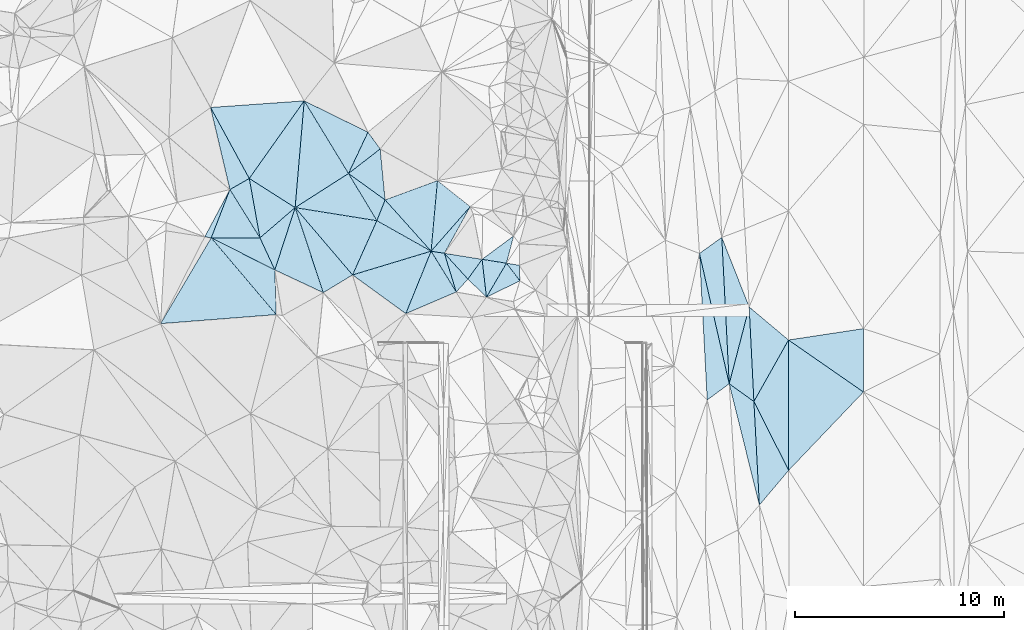
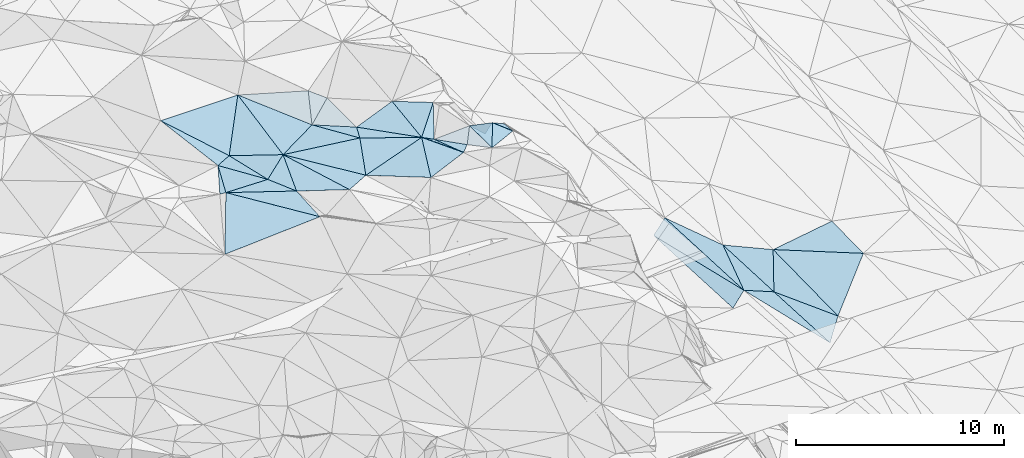
# One storey, part 84 of 275: 45 plates.
"""IFC2X3 building model written with IfcOpenShell, lengths in millimetres."""

from ifc_helpers import new_model, si_unit, frame, origin_with_axes, place, context, subcontext, project, spatial, polyline, outline, extrude, material, type_object, element, save


model = new_model("IFC2X3")

# Units and contexts
model_context = context("Model", 3, precision=1e-05, world=origin_with_axes())
body_context = subcontext(model_context, "Body", "Model", "MODEL_VIEW")
ifc_project = project(units=[si_unit("LENGTHUNIT", "METRE", prefix="MILLI"), si_unit("AREAUNIT", "SQUARE_METRE"), si_unit("VOLUMEUNIT", "CUBIC_METRE"), si_unit("MASSUNIT", "GRAM", prefix="KILO"), si_unit("TIMEUNIT", "SECOND"), si_unit("PLANEANGLEUNIT", "RADIAN"), si_unit("SOLIDANGLEUNIT", "STERADIAN"), si_unit("THERMODYNAMICTEMPERATUREUNIT", "DEGREE_CELSIUS"), si_unit("LUMINOUSINTENSITYUNIT", "LUMEN")], contexts=[model_context])

# Site, building, storey
site_placement = place(None, origin_with_axes())
site = spatial("IfcSite", under=ifc_project, at=site_placement, CompositionType="ELEMENT")
building_placement = place(site_placement, origin_with_axes())
building = spatial("IfcBuilding", under=site, at=building_placement, Name="Undefined", CompositionType="ELEMENT")
storey_placement = place(building_placement, origin_with_axes())
storey = spatial("IfcBuildingStorey", under=building, at=storey_placement, Name="Undefined", CompositionType="ELEMENT", Elevation=0.0)

# Plates
ifc_material = material()
plate_type_1 = type_object("IfcPlateType", PredefinedType="NOTDEFINED")
plate_1_placement = place(storey_placement, frame((-108386.580051783, 88862.7996811773, 52679.50220906), z_axis=(-0.0473780441127211, -0.0815394094291128, -0.995543392146221), x_axis=(0.811245497660078, -0.584632094449101, 0.00927667323509588)))
element("IfcPlate", 1, at=plate_1_placement, inside=storey, type_object=plate_type_1, material=ifc_material, Name="00", context=body_context, shape_type="SweptSolid", body=[
    extrude(outline(polyline([(0.0, 0.0), (2155.9453125, 1.20780896395445e-09), (2419.68115234375, 1039.49194335938), (0.0, 0.0)])), frame((-8.85201319254618e-08, 2.18876761149539e-07, -0.5000001331573), z_axis=(0.0, 0.0, 1.0), x_axis=(1.0, 0.0, 0.0)), (0.0, 0.0, 1.0), 1.0),
])
plate_type_2 = type_object("IfcPlateType", PredefinedType="NOTDEFINED")
plate_2_placement = place(storey_placement, frame((-110935.188256304, 87233.1552886086, 52809.5025149731), z_axis=(0.0909211524705096, 0.0429663560057354, -0.994930769594057), x_axis=(-0.842542661091753, 0.535930910773084, -0.0538509342385081)))
element("IfcPlate", 2, at=plate_2_placement, inside=storey, type_object=plate_type_2, material=ifc_material, Name="00", context=body_context, shape_type="SweptSolid", body=[
    extrude(outline(polyline([(0.0, 0.0), (2599.76928710938, 2.09729478228837e-09), (2353.90112304688, 4553.94873046875), (0.0, 0.0)])), frame((-8.85201319254618e-08, 2.18876761149539e-07, -0.5000001331573), z_axis=(0.0, 0.0, 1.0), x_axis=(1.0, 0.0, 0.0)), (0.0, 0.0, 1.0), 1.0),
])
plate_type_3 = type_object("IfcPlateType", PredefinedType="NOTDEFINED")
plate_3_placement = place(storey_placement, frame((-114050.664548949, 88097.1968443892, 52739.5005654492), z_axis=(-0.0171309228286942, -0.0453009128549902, -0.998826490826881), x_axis=(0.52807049744489, -0.848690256273745, 0.029434650232553)))
element("IfcPlate", 3, at=plate_3_placement, inside=storey, type_object=plate_type_3, material=ifc_material, Name="00", context=body_context, shape_type="SweptSolid", body=[
    extrude(outline(polyline([(0.0, 0.0), (2717.88525390625, -1.81898940354586e-09), (1490.90185546875, 1979.04309082031), (0.0, 0.0)])), frame((-8.85201319254618e-08, 2.18876761149539e-07, -0.5000001331573), z_axis=(0.0, 0.0, 1.0), x_axis=(1.0, 0.0, 0.0)), (0.0, 0.0, 1.0), 1.0),
])
plate_type_4 = type_object("IfcPlateType", PredefinedType="NOTDEFINED")
plate_4_placement = place(storey_placement, frame((-112615.44152599, 85790.5467316881, 52819.5013071815), z_axis=(-0.0410658751826201, -0.0601422838124881, -0.997344724552802), x_axis=(-0.528070497442387, 0.848690256275381, -0.0294346502302673)))
element("IfcPlate", 4, at=plate_4_placement, inside=storey, type_object=plate_type_4, material=ifc_material, Name="00", context=body_context, shape_type="SweptSolid", body=[
    extrude(outline(polyline([(0.0, 0.0), (2717.88525390625, -1.81898940354586e-09), (2680.61352539063, 1067.33825683594), (0.0, 0.0)])), frame((-8.85201319254618e-08, 2.18876761149539e-07, -0.5000001331573), z_axis=(0.0, 0.0, 1.0), x_axis=(1.0, 0.0, 0.0)), (0.0, 0.0, 1.0), 1.0),
])
plate_type_5 = type_object("IfcPlateType", PredefinedType="NOTDEFINED")
plate_5_placement = place(storey_placement, frame((-104439.082211446, 85152.0740761897, 52809.5021817556), z_axis=(-0.0429967599848049, -0.0832734143644725, -0.995598722925503), x_axis=(-0.871575199290287, 0.490250293904377, -0.00336471525813851)))
element("IfcPlate", 5, at=plate_5_placement, inside=storey, type_object=plate_type_5, material=ifc_material, Name="00", context=body_context, shape_type="SweptSolid", body=[
    extrude(outline(polyline([(0.0, 0.0), (2972.01953125, -9.47693479247391e-09), (3117.77905273438, 1062.47546386719), (0.0, 0.0)])), frame((-8.85201319254618e-08, 2.18876761149539e-07, -0.5000001331573), z_axis=(0.0, 0.0, 1.0), x_axis=(1.0, 0.0, 0.0)), (0.0, 0.0, 1.0), 1.0),
])
plate_type_6 = type_object("IfcPlateType", PredefinedType="NOTDEFINED")
plate_6_placement = place(storey_placement, frame((-87365.5688585575, 80909.3780213733, 42819.5002070441), z_axis=(0.0221465759152857, 0.0198452153937442, -0.999557750508296), x_axis=(0.98839121279668, 0.149880120603403, 0.0248748852101583)))
element("IfcPlate", 6, at=plate_6_placement, inside=storey, type_object=plate_type_6, material=ifc_material, Name="00", context=body_context, shape_type="SweptSolid", body=[
    extrude(outline(polyline([(0.0, 0.0), (3618.10717773438, -2.9831426218152e-09), (3167.12548828125, 2993.5791015625), (0.0, 0.0)])), frame((-8.85201319254618e-08, 2.18876761149539e-07, -0.5000001331573), z_axis=(0.0, 0.0, 1.0), x_axis=(1.0, 0.0, 0.0)), (0.0, 0.0, 1.0), 1.0),
])
plate_type_7 = type_object("IfcPlateType", PredefinedType="NOTDEFINED")
plate_7_placement = place(storey_placement, frame((-90196.6322116075, 78818.0444461295, 42687.5079163756), z_axis=(0.174846447314894, 0.0298121499985753, -0.984144275791829), x_axis=(-0.795259158075311, -0.585045632729329, -0.15901094025785)))
element("IfcPlate", 7, at=plate_7_placement, inside=storey, type_object=plate_type_7, material=ifc_material, Name="00", context=body_context, shape_type="SweptSolid", body=[
    extrude(outline(polyline([(0.0, 0.0), (1320.66381835938, 1.06228981167078e-09), (-2501.51391601563, 5876.05078125), (0.0, 0.0)])), frame((-8.85201319254618e-08, 2.18876761149539e-07, -0.5000001331573), z_axis=(0.0, 0.0, 1.0), x_axis=(1.0, 0.0, 0.0)), (0.0, 0.0, 1.0), 1.0),
])
plate_type_8 = type_object("IfcPlateType", PredefinedType="NOTDEFINED")
plate_8_placement = place(storey_placement, frame((-102569.851096653, 87279.8264456317, 52919.5566958775), z_axis=(-0.323814668468676, 0.33035846241017, -0.886570553762367), x_axis=(-0.478982492871626, -0.865343068309801, -0.147503036072694)))
element("IfcPlate", 8, at=plate_8_placement, inside=storey, type_object=plate_type_8, material=ifc_material, Name="00", context=body_context, shape_type="SweptSolid", body=[
    extrude(outline(polyline([(0.0, 0.0), (2576.21826171875, 2.00525391846895e-08), (2752.67846679688, 675.175354003906), (0.0, 0.0)])), frame((-8.85201319254618e-08, 2.18876761149539e-07, -0.5000001331573), z_axis=(0.0, 0.0, 1.0), x_axis=(1.0, 0.0, 0.0)), (0.0, 0.0, 1.0), 1.0),
])
plate_type_9 = type_object("IfcPlateType", PredefinedType="NOTDEFINED")
plate_9_placement = place(storey_placement, frame((-90196.7069356175, 78818.0401369542, 42687.5002602962), z_axis=(0.0254223780452323, 0.0211891597521177, -0.999452211065404), x_axis=(0.251652546433601, 0.967443413523056, 0.0269116611219287)))
element("IfcPlate", 9, at=plate_9_placement, inside=storey, type_object=plate_type_9, material=ifc_material, Name="00", context=body_context, shape_type="SweptSolid", body=[
    extrude(outline(polyline([(0.0, 0.0), (3790.17846679688, 9.61881596595049e-09), (-523.401977539063, 1354.22424316406), (0.0, 0.0)])), frame((-8.85201319254618e-08, 2.18876761149539e-07, -0.5000001331573), z_axis=(0.0, 0.0, 1.0), x_axis=(1.0, 0.0, 0.0)), (0.0, 0.0, 1.0), 1.0),
])
plate_type_10 = type_object("IfcPlateType", PredefinedType="NOTDEFINED")
plate_10_placement = place(storey_placement, frame((-89242.8945265137, 82484.823568676, 42789.5003946455), z_axis=(0.0341071068266466, 0.021616004348828, -0.999184394203546), x_axis=(0.765951622118236, -0.642781685216068, 0.0122400051157735)))
element("IfcPlate", 10, at=plate_10_placement, inside=storey, type_object=plate_type_10, material=ifc_material, Name="00", context=body_context, shape_type="SweptSolid", body=[
    extrude(outline(polyline([(0.0, 0.0), (2450.9794921875, 5.77529135625809e-10), (3072.93481445313, 3316.31884765625), (0.0, 0.0)])), frame((-8.85201319254618e-08, 2.18876761149539e-07, -0.5000001331573), z_axis=(0.0, 0.0, 1.0), x_axis=(1.0, 0.0, 0.0)), (0.0, 0.0, 1.0), 1.0),
])
plate_type_11 = type_object("IfcPlateType", PredefinedType="NOTDEFINED")
plate_11_placement = place(storey_placement, frame((-114943.62580473, 85789.0516893204, 52859.5000689306), z_axis=(-0.0171724047605289, -0.00795913818449715, -0.999820864272246), x_axis=(0.999852231399842, 0.000653254230612618, -0.0171781437782944)))
element("IfcPlate", 11, at=plate_11_placement, inside=storey, type_object=plate_type_11, material=ifc_material, Name="00", context=body_context, shape_type="SweptSolid", body=[
    extrude(outline(polyline([(0.0, 0.0), (2328.54028320313, -1.19325704872608e-09), (3038.21240234375, 1534.068359375), (0.0, 0.0)])), frame((-8.85201319254618e-08, 2.18876761149539e-07, -0.5000001331573), z_axis=(0.0, 0.0, 1.0), x_axis=(1.0, 0.0, 0.0)), (0.0, 0.0, 1.0), 1.0),
])
plate_type_12 = type_object("IfcPlateType", PredefinedType="NOTDEFINED")
plate_12_placement = place(storey_placement, frame((-100496.145371751, 85878.1015995437, 51179.67594565), z_axis=(-0.184249683621059, -0.738953221485208, -0.648074216847247), x_axis=(-0.165664651089674, -0.626581207265257, 0.761545280388074)))
element("IfcPlate", 12, at=plate_12_placement, inside=storey, type_object=plate_type_12, material=ifc_material, Name="00", context=body_context, shape_type="SweptSolid", body=[
    extrude(outline(polyline([(0.0, 0.0), (2074.72900390625, 2.35741026699543e-09), (2243.0400390625, 1172.93286132813), (0.0, 0.0)])), frame((-8.85201319254618e-08, 2.18876761149539e-07, -0.5000001331573), z_axis=(0.0, 0.0, 1.0), x_axis=(1.0, 0.0, 0.0)), (0.0, 0.0, 1.0), 1.0),
])
plate_type_13 = type_object("IfcPlateType", PredefinedType="NOTDEFINED")
plate_13_placement = place(storey_placement, frame((-90196.7075435128, 78818.0392869851, 42687.5002243836), z_axis=(0.0241860014844724, 0.0194698134309543, -0.999517865621799), x_axis=(0.811704490584274, -0.584009849785009, 0.00826530818629343)))
element("IfcPlate", 13, at=plate_13_placement, inside=storey, type_object=plate_type_13, material=ifc_material, Name="00", context=body_context, shape_type="SweptSolid", body=[
    extrude(outline(polyline([(0.0, 0.0), (1451.8515625, -1.21181074064225e-08), (4552.7744140625, 3863.53149414063), (0.0, 0.0)])), frame((-8.85201319254618e-08, 2.18876761149539e-07, -0.5000001331573), z_axis=(0.0, 0.0, 1.0), x_axis=(1.0, 0.0, 0.0)), (0.0, 0.0, 1.0), 1.0),
])
plate_type_14 = type_object("IfcPlateType", PredefinedType="NOTDEFINED")
plate_14_placement = place(storey_placement, frame((-103803.692304363, 85050.29638164, 52539.5043197901), z_axis=(-0.079431329158167, -0.104732474381509, -0.991323243325856), x_axis=(0.674026666099184, -0.738317198775976, 0.0239951532359128)))
element("IfcPlate", 14, at=plate_14_placement, inside=storey, type_object=plate_type_14, material=ifc_material, Name="00", context=body_context, shape_type="SweptSolid", body=[
    extrude(outline(polyline([(0.0, 0.0), (1667.00329589844, 1.21508492156863e-08), (1750.26647949219, 835.683715820313), (0.0, 0.0)])), frame((-8.85201319254618e-08, 2.18876761149539e-07, -0.5000001331573), z_axis=(0.0, 0.0, 1.0), x_axis=(1.0, 0.0, 0.0)), (0.0, 0.0, 1.0), 1.0),
])
plate_type_15 = type_object("IfcPlateType", PredefinedType="NOTDEFINED")
plate_15_placement = place(storey_placement, frame((-101794.235559156, 82953.8547880419, 52609.5168145792), z_axis=(0.195836438012691, 0.166857271893424, -0.966336763433321), x_axis=(-0.714890506026088, 0.698817032693059, -0.024214029235816)))
element("IfcPlate", 15, at=plate_15_placement, inside=storey, type_object=plate_type_15, material=ifc_material, Name="00", context=body_context, shape_type="SweptSolid", body=[
    extrude(outline(polyline([(0.0, 0.0), (1238.951171875, -1.43700162880123e-09), (1408.04577636719, 1187.2265625), (0.0, 0.0)])), frame((-8.85201319254618e-08, 2.18876761149539e-07, -0.5000001331573), z_axis=(0.0, 0.0, 1.0), x_axis=(1.0, 0.0, 0.0)), (0.0, 0.0, 1.0), 1.0),
])
plate_type_16 = type_object("IfcPlateType", PredefinedType="NOTDEFINED")
plate_16_placement = place(storey_placement, frame((-102004.043375566, 84763.6023774129, 52879.5063794252), z_axis=(-0.079812946958229, 0.13803544257929, -0.987206214572104), x_axis=(0.98252557942757, -0.156165956834787, -0.101270329793049)))
element("IfcPlate", 16, at=plate_16_placement, inside=storey, type_object=plate_type_16, material=ifc_material, Name="00", context=body_context, shape_type="SweptSolid", body=[
    extrude(outline(polyline([(0.0, 0.0), (1184.947265625, 1.03318598121405e-09), (515.972351074219, 1768.013671875), (0.0, 0.0)])), frame((-8.85201319254618e-08, 2.18876761149539e-07, -0.5000001331573), z_axis=(0.0, 0.0, 1.0), x_axis=(1.0, 0.0, 0.0)), (0.0, 0.0, 1.0), 1.0),
])
plate_type_17 = type_object("IfcPlateType", PredefinedType="NOTDEFINED")
plate_17_placement = place(storey_placement, frame((-100839.934150185, 84578.4648306573, 52759.5308060635), z_axis=(-0.343332692926057, -0.0402186716529135, -0.938352343428958), x_axis=(0.930179919547813, -0.152798132893854, -0.333793420927041)))
element("IfcPlate", 17, at=plate_17_placement, inside=storey, type_object=plate_type_17, material=ifc_material, Name="00", context=body_context, shape_type="SweptSolid", body=[
    extrude(outline(polyline([(0.0, 0.0), (659.090270996094, 3.01224645227194e-09), (795.338684082031, 728.585205078125), (0.0, 0.0)])), frame((-8.85201319254618e-08, 2.18876761149539e-07, -0.5000001331573), z_axis=(0.0, 0.0, 1.0), x_axis=(1.0, 0.0, 0.0)), (0.0, 0.0, 1.0), 1.0),
])
plate_type_18 = type_object("IfcPlateType", PredefinedType="NOTDEFINED")
plate_18_placement = place(storey_placement, frame((-91618.3886218002, 85043.8021222997, 42623.5073159665), z_axis=(0.168211243000226, 0.0282845492018912, -0.985345097924968), x_axis=(0.802293724824646, 0.576850243562442, 0.153520603206693)))
element("IfcPlate", 18, at=plate_18_placement, inside=storey, type_object=plate_type_18, material=ifc_material, Name="00", context=body_context, shape_type="SweptSolid", body=[
    extrude(outline(polyline([(0.0, 0.0), (1328.81188964844, 3.87080945074558e-09), (-2440.84130859375, 5901.51171875), (0.0, 0.0)])), frame((-8.85201319254618e-08, 2.18876761149539e-07, -0.5000001331573), z_axis=(0.0, 0.0, 1.0), x_axis=(1.0, 0.0, 0.0)), (0.0, 0.0, 1.0), 1.0),
])
plate_type_19 = type_object("IfcPlateType", PredefinedType="NOTDEFINED")
plate_19_placement = place(storey_placement, frame((-100839.815333368, 84578.5613084166, 52759.5086729945), z_axis=(-0.105539493372001, 0.1527269008104, -0.982616867913243), x_axis=(0.598108272684796, -0.779669487932432, -0.185423794948729)))
element("IfcPlate", 19, at=plate_19_placement, inside=storey, type_object=plate_type_19, material=ifc_material, Name="00", context=body_context, shape_type="SweptSolid", body=[
    extrude(outline(polyline([(0.0, 0.0), (1078.61022949219, 3.09591996483505e-09), (723.616333007813, 1746.36169433594), (0.0, 0.0)])), frame((-8.85201319254618e-08, 2.18876761149539e-07, -0.5000001331573), z_axis=(0.0, 0.0, 1.0), x_axis=(1.0, 0.0, 0.0)), (0.0, 0.0, 1.0), 1.0),
])
plate_type_20 = type_object("IfcPlateType", PredefinedType="NOTDEFINED")
plate_20_placement = place(storey_placement, frame((-103237.877538802, 83201.2051087369, 52689.5547884111), z_axis=(-0.410015527839808, -0.197733789193882, -0.890386778619984), x_axis=(-0.523660923465364, 0.850319565303489, 0.0523055838079288)))
element("IfcPlate", 20, at=plate_20_placement, inside=storey, type_object=plate_type_20, material=ifc_material, Name="00", context=body_context, shape_type="SweptSolid", body=[
    extrude(outline(polyline([(0.0, 0.0), (2294.21020507813, 9.95351001620293e-09), (1860.81469726563, 546.962951660156), (0.0, 0.0)])), frame((-8.85201319254618e-08, 2.18876761149539e-07, -0.5000001331573), z_axis=(0.0, 0.0, 1.0), x_axis=(1.0, 0.0, 0.0)), (0.0, 0.0, 1.0), 1.0),
])
plate_type_21 = type_object("IfcPlateType", PredefinedType="NOTDEFINED")
plate_21_placement = place(storey_placement, frame((-103803.548797934, 85050.4278144353, 52539.5173054603), z_axis=(0.207581799523381, 0.158132446715465, -0.965351710933593), x_axis=(0.97078564103455, -0.154716970771224, 0.18340637425268)))
element("IfcPlate", 21, at=plate_21_placement, inside=storey, type_object=plate_type_21, material=ifc_material, Name="00", context=body_context, shape_type="SweptSolid", body=[
    extrude(outline(polyline([(0.0, 0.0), (1853.80688476563, 4.46743797510862e-09), (1288.53771972656, 1057.625), (0.0, 0.0)])), frame((-8.85201319254618e-08, 2.18876761149539e-07, -0.5000001331573), z_axis=(0.0, 0.0, 1.0), x_axis=(1.0, 0.0, 0.0)), (0.0, 0.0, 1.0), 1.0),
])
plate_type_22 = type_object("IfcPlateType", PredefinedType="NOTDEFINED")
plate_22_placement = place(storey_placement, frame((-108190.947801121, 84018.2621437385, 52589.5013674836), z_axis=(0.039382820234934, 0.0631712203224884, -0.997225345843812), x_axis=(0.407977379961261, 0.910007789585465, 0.0737582560376859)))
element("IfcPlate", 22, at=plate_22_placement, inside=storey, type_object=plate_type_22, material=ifc_material, Name="00", context=body_context, shape_type="SweptSolid", body=[
    extrude(outline(polyline([(0.0, 0.0), (2847.13891601563, -5.64614310860634e-09), (2578.76416015625, 2959.87744140625), (0.0, 0.0)])), frame((-8.85201319254618e-08, 2.18876761149539e-07, -0.5000001331573), z_axis=(0.0, 0.0, 1.0), x_axis=(1.0, 0.0, 0.0)), (0.0, 0.0, 1.0), 1.0),
])
plate_type_23 = type_object("IfcPlateType", PredefinedType="NOTDEFINED")
plate_23_placement = place(storey_placement, frame((-114943.619149979, 85789.0921033081, 52859.5013126928), z_axis=(-0.00388868035268274, 0.0728686466082565, -0.997333965383008), x_axis=(0.645517390053446, -0.761528126703473, -0.0581567827350032)))
element("IfcPlate", 23, at=plate_23_placement, inside=storey, type_object=plate_type_23, material=ifc_material, Name="00", context=body_context, shape_type="SweptSolid", body=[
    extrude(outline(polyline([(0.0, 0.0), (4814.57177734375, -8.30186763778329e-09), (1575.98657226563, 4500.0185546875), (0.0, 0.0)])), frame((-8.85201319254618e-08, 2.18876761149539e-07, -0.5000001331573), z_axis=(0.0, 0.0, 1.0), x_axis=(1.0, 0.0, 0.0)), (0.0, 0.0, 1.0), 1.0),
])
plate_type_24 = type_object("IfcPlateType", PredefinedType="NOTDEFINED")
plate_24_placement = place(storey_placement, frame((-104439.071114851, 85152.1400095212, 52809.5006813522), z_axis=(-0.0208248110341935, 0.0486020499990452, -0.998601105537782), x_axis=(0.523660923467584, -0.85031956530281, -0.0523055837967336)))
element("IfcPlate", 24, at=plate_24_placement, inside=storey, type_object=plate_type_24, material=ifc_material, Name="00", context=body_context, shape_type="SweptSolid", body=[
    extrude(outline(polyline([(0.0, 0.0), (2294.21020507813, 9.95351001620293e-09), (1910.50500488281, 2591.92407226563), (0.0, 0.0)])), frame((-8.85201319254618e-08, 2.18876761149539e-07, -0.5000001331573), z_axis=(0.0, 0.0, 1.0), x_axis=(1.0, 0.0, 0.0)), (0.0, 0.0, 1.0), 1.0),
])
plate_type_25 = type_object("IfcPlateType", PredefinedType="NOTDEFINED")
plate_25_placement = place(storey_placement, frame((-109587.732705049, 83171.1292379902, 52749.5001789872), z_axis=(-0.0275663468032675, 0.00562042020970078, -0.999604175361722), x_axis=(-0.905144797437824, 0.424222883953875, 0.0273466707497939)))
element("IfcPlate", 25, at=plate_25_placement, inside=storey, type_object=plate_type_25, material=ifc_material, Name="00", context=body_context, shape_type="SweptSolid", body=[
    extrude(outline(polyline([(0.0, 0.0), (2559.7265625, 1.80807546712458e-09), (2944.533203125, 3106.28784179688), (0.0, 0.0)])), frame((-8.85201319254618e-08, 2.18876761149539e-07, -0.5000001331573), z_axis=(0.0, 0.0, 1.0), x_axis=(1.0, 0.0, 0.0)), (0.0, 0.0, 1.0), 1.0),
])
plate_26_placement = place(storey_placement, frame((-108386.497309168, 88862.9312482766, 52679.5118522026), z_axis=(0.118098477560666, 0.181597927885993, -0.976255572166104), x_axis=(-0.517770164145949, 0.850171756804636, 0.0955093767752439)))
element("IfcPlate", 26, at=plate_26_placement, inside=storey, type_object=plate_type_25, material=ifc_material, Name="00", context=body_context, shape_type="SweptSolid", body=[
    extrude(outline(polyline([(0.0, 0.0), (4083.36865234375, 3.06172296404839e-08), (1242.99328613281, 1858.16247558594), (0.0, 0.0)])), frame((-8.85201319254618e-08, 2.18876761149539e-07, -0.5000001331573), z_axis=(0.0, 0.0, 1.0), x_axis=(1.0, 0.0, 0.0)), (0.0, 0.0, 1.0), 1.0),
])
plate_type_26 = type_object("IfcPlateType", PredefinedType="NOTDEFINED")
plate_27_placement = place(storey_placement, frame((-110935.228882847, 87233.1720420922, 52809.5014679808), z_axis=(0.00966524728515323, 0.0764780040069057, -0.997024421916553), x_axis=(0.98747487307498, -0.157756087763076, -0.0025282047465476)))
element("IfcPlate", 27, at=plate_27_placement, inside=storey, type_object=plate_type_26, material=ifc_material, Name="00", context=body_context, shape_type="SweptSolid", body=[
    extrude(outline(polyline([(0.0, 0.0), (3955.3759765625, -1.86701072379947e-08), (3217.62060546875, 2749.89404296875), (0.0, 0.0)])), frame((-8.85201319254618e-08, 2.18876761149539e-07, -0.5000001331573), z_axis=(0.0, 0.0, 1.0), x_axis=(1.0, 0.0, 0.0)), (0.0, 0.0, 1.0), 1.0),
])
plate_type_27 = type_object("IfcPlateType", PredefinedType="NOTDEFINED")
plate_28_placement = place(storey_placement, frame((-111835.705546149, 82122.680471372, 52579.5036705222), z_axis=(0.0439175419480246, 0.113032119386767, -0.992620264500065), x_axis=(-0.645517390070698, 0.761528126687722, 0.0581567827497589)))
element("IfcPlate", 28, at=plate_28_placement, inside=storey, type_object=plate_type_27, material=ifc_material, Name="00", context=body_context, shape_type="SweptSolid", body=[
    extrude(outline(polyline([(0.0, 0.0), (4814.57177734375, -8.30186763778329e-09), (1683.84655761719, 1335.16320800781), (0.0, 0.0)])), frame((-8.85201319254618e-08, 2.18876761149539e-07, -0.5000001331573), z_axis=(0.0, 0.0, 1.0), x_axis=(1.0, 0.0, 0.0)), (0.0, 0.0, 1.0), 1.0),
])
plate_type_28 = type_object("IfcPlateType", PredefinedType="NOTDEFINED")
plate_29_placement = place(storey_placement, frame((-114975.116809154, 92018.3344901174, 53319.5080506407), z_axis=(-0.138970277764861, 0.112768761218131, -0.983854902102584), x_axis=(0.472076926357198, -0.865802681136365, -0.165918934839342)))
element("IfcPlate", 29, at=plate_29_placement, inside=storey, type_object=plate_type_28, material=ifc_material, Name="00", context=body_context, shape_type="SweptSolid", body=[
    extrude(outline(polyline([(0.0, 0.0), (3917.57568359375, 9.03673935681582e-09), (3927.47998046875, 1067.94287109375), (0.0, 0.0)])), frame((-8.85201319254618e-08, 2.18876761149539e-07, -0.5000001331573), z_axis=(0.0, 0.0, 1.0), x_axis=(1.0, 0.0, 0.0)), (0.0, 0.0, 1.0), 1.0),
])
plate_type_29 = type_object("IfcPlateType", PredefinedType="NOTDEFINED")
plate_30_placement = place(storey_placement, frame((-111904.644225525, 84257.0200206297, 52819.4999860023), z_axis=(-0.00425746446713632, -0.00197326776800877, -0.999988990044704), x_axis=(-0.420512976306107, 0.907286524069535, -1.99704337322955e-10)))
element("IfcPlate", 30, at=plate_30_placement, inside=storey, type_object=plate_type_29, material=ifc_material, Name="00", context=body_context, shape_type="SweptSolid", body=[
    extrude(outline(polyline([(0.0, 0.0), (1690.26623535156, -1.41590135172009e-08), (2292.53833007813, 2131.04858398438), (0.0, 0.0)])), frame((-8.85201319254618e-08, 2.18876761149539e-07, -0.5000001331573), z_axis=(0.0, 0.0, 1.0), x_axis=(1.0, 0.0, 0.0)), (0.0, 0.0, 1.0), 1.0),
])
plate_type_30 = type_object("IfcPlateType", PredefinedType="NOTDEFINED")
plate_31_placement = place(storey_placement, frame((-114050.64468482, 88097.1891823581, 52739.5010267622), z_axis=(0.0225959808703213, -0.0606221848125656, -0.997904991648533), x_axis=(-0.360387435734755, -0.931544625929087, 0.0484304250153309)))
element("IfcPlate", 31, at=plate_31_placement, inside=storey, type_object=plate_type_30, material=ifc_material, Name="00", context=body_context, shape_type="SweptSolid", body=[
    extrude(outline(polyline([(0.0, 0.0), (2477.78125, -2.70665623247623e-09), (2540.86181640625, 304.336700439453), (0.0, 0.0)])), frame((-8.85201319254618e-08, 2.18876761149539e-07, -0.5000001331573), z_axis=(0.0, 0.0, 1.0), x_axis=(1.0, 0.0, 0.0)), (0.0, 0.0, 1.0), 1.0),
])
plate_type_31 = type_object("IfcPlateType", PredefinedType="NOTDEFINED")
plate_32_placement = place(storey_placement, frame((-104439.042496764, 85152.1096273866, 52809.5003501096), z_axis=(0.036432415555792, -0.0121709457058364, -0.999262001267633), x_axis=(-0.667455895850086, 0.743900099503683, -0.0333956442275059)))
element("IfcPlate", 32, at=plate_32_placement, inside=storey, type_object=plate_type_31, material=ifc_material, Name="00", context=body_context, shape_type="SweptSolid", body=[
    extrude(outline(polyline([(0.0, 0.0), (3293.8427734375, 2.59387888945639e-09), (2305.90844726563, 2476.8701171875), (0.0, 0.0)])), frame((-8.85201319254618e-08, 2.18876761149539e-07, -0.5000001331573), z_axis=(0.0, 0.0, 1.0), x_axis=(1.0, 0.0, 0.0)), (0.0, 0.0, 1.0), 1.0),
])
plate_type_32 = type_object("IfcPlateType", PredefinedType="NOTDEFINED")
plate_33_placement = place(storey_placement, frame((-108190.941053848, 84018.2399488011, 52589.5007681111), z_axis=(0.0528710219463386, 0.0187729144707353, -0.998424875852272), x_axis=(0.955736204306891, 0.288838490334365, 0.0560413622106128)))
element("IfcPlate", 33, at=plate_33_placement, inside=storey, type_object=plate_type_32, material=ifc_material, Name="00", context=body_context, shape_type="SweptSolid", body=[
    extrude(outline(polyline([(0.0, 0.0), (3925.671875, 8.13452061265707e-09), (1903.82690429688, 2506.04125976563), (0.0, 0.0)])), frame((-8.85201319254618e-08, 2.18876761149539e-07, -0.5000001331573), z_axis=(0.0, 0.0, 1.0), x_axis=(1.0, 0.0, 0.0)), (0.0, 0.0, 1.0), 1.0),
])
plate_type_33 = type_object("IfcPlateType", PredefinedType="NOTDEFINED")
plate_34_placement = place(storey_placement, frame((-113125.633130304, 88626.4071614112, 52669.5008159407), z_axis=(0.0341242266044759, -0.0466660011787229, -0.998327512138493), x_axis=(0.842542661096068, -0.535930910766295, 0.0538509342385591)))
element("IfcPlate", 34, at=plate_34_placement, inside=storey, type_object=plate_type_33, material=ifc_material, Name="00", context=body_context, shape_type="SweptSolid", body=[
    extrude(outline(polyline([(0.0, 0.0), (2599.76928710938, 2.09729478228837e-09), (1957.78918457031, 2119.4248046875), (0.0, 0.0)])), frame((-8.85201319254618e-08, 2.18876761149539e-07, -0.5000001331573), z_axis=(0.0, 0.0, 1.0), x_axis=(1.0, 0.0, 0.0)), (0.0, 0.0, 1.0), 1.0),
])
plate_type_34 = type_object("IfcPlateType", PredefinedType="NOTDEFINED")
plate_35_placement = place(storey_placement, frame((-104439.022411876, 85152.1078303685, 52809.501513471), z_axis=(0.0766028365728152, -0.0157628033599301, -0.996937078987052), x_axis=(0.0895656547289487, 0.995941466796266, -0.00886499907933091)))
element("IfcPlate", 35, at=plate_35_placement, inside=storey, type_object=plate_type_34, material=ifc_material, Name="00", context=body_context, shape_type="SweptSolid", body=[
    extrude(outline(polyline([(0.0, 0.0), (3384.09521484375, 1.04773789644241e-09), (2285.3671875, 1676.36413574219), (0.0, 0.0)])), frame((-8.85201319254618e-08, 2.18876761149539e-07, -0.5000001331573), z_axis=(0.0, 0.0, 1.0), x_axis=(1.0, 0.0, 0.0)), (0.0, 0.0, 1.0), 1.0),
])
plate_type_35 = type_object("IfcPlateType", PredefinedType="NOTDEFINED")
plate_36_placement = place(storey_placement, frame((-110935.284850461, 87233.1241864925, 52809.5026935832), z_axis=(-0.102264567662067, -0.0192340221795908, -0.994571269739723), x_axis=(0.648362420193751, -0.759555478832517, -0.051977366766767)))
element("IfcPlate", 36, at=plate_36_placement, inside=storey, type_object=plate_type_35, material=ifc_material, Name="00", context=body_context, shape_type="SweptSolid", body=[
    extrude(outline(polyline([(0.0, 0.0), (4232.611328125, 8.38190317153931e-09), (3962.11645507813, 1618.92944335938), (0.0, 0.0)])), frame((-8.85201319254618e-08, 2.18876761149539e-07, -0.5000001331573), z_axis=(0.0, 0.0, 1.0), x_axis=(1.0, 0.0, 0.0)), (0.0, 0.0, 1.0), 1.0),
])
plate_type_36 = type_object("IfcPlateType", PredefinedType="NOTDEFINED")
plate_37_placement = place(storey_placement, frame((-106637.499342742, 87602.4757319184, 52699.508108005), z_axis=(0.112258544333662, 0.140162277078866, -0.983744151346352), x_axis=(-0.81124549766041, 0.584632094448409, -0.0092766732496751)))
element("IfcPlate", 37, at=plate_37_placement, inside=storey, type_object=plate_type_36, material=ifc_material, Name="00", context=body_context, shape_type="SweptSolid", body=[
    extrude(outline(polyline([(0.0, 0.0), (2155.9453125, 1.20780896395445e-09), (1609.27087402344, 1867.60461425781), (0.0, 0.0)])), frame((-8.85201319254618e-08, 2.18876761149539e-07, -0.5000001331573), z_axis=(0.0, 0.0, 1.0), x_axis=(1.0, 0.0, 0.0)), (0.0, 0.0, 1.0), 1.0),
])
plate_type_37 = type_object("IfcPlateType", PredefinedType="NOTDEFINED")
plate_38_placement = place(storey_placement, frame((-108386.56246986, 88862.8101969258, 52679.5009335227), z_axis=(-0.0122213398273442, -0.0605040519011654, -0.99809313120388), x_axis=(0.515340626459626, -0.855773179357589, 0.0455664812378989)))
element("IfcPlate", 38, at=plate_38_placement, inside=storey, type_object=plate_type_37, material=ifc_material, Name="00", context=body_context, shape_type="SweptSolid", body=[
    extrude(outline(polyline([(0.0, 0.0), (2633.5146484375, 1.87283148989081e-08), (87.1458969116211, 3026.71533203125), (0.0, 0.0)])), frame((-8.85201319254618e-08, 2.18876761149539e-07, -0.5000001331573), z_axis=(0.0, 0.0, 1.0), x_axis=(1.0, 0.0, 0.0)), (0.0, 0.0, 1.0), 1.0),
])
plate_type_38 = type_object("IfcPlateType", PredefinedType="NOTDEFINED")
plate_39_placement = place(storey_placement, frame((-110500.846814551, 92334.4342829323, 53069.5027634019), z_axis=(-0.0879190218842317, 0.0581709753385426, -0.994427666157314), x_axis=(0.517770164140918, -0.850171756802297, -0.095509376823346)))
element("IfcPlate", 39, at=plate_39_placement, inside=storey, type_object=plate_type_38, material=ifc_material, Name="00", context=body_context, shape_type="SweptSolid", body=[
    extrude(outline(polyline([(0.0, 0.0), (4083.36865234375, 3.06172296404839e-08), (4136.85400390625, 3027.49731445313), (0.0, 0.0)])), frame((-8.85201319254618e-08, 2.18876761149539e-07, -0.5000001331573), z_axis=(0.0, 0.0, 1.0), x_axis=(1.0, 0.0, 0.0)), (0.0, 0.0, 1.0), 1.0),
])
plate_type_39 = type_object("IfcPlateType", PredefinedType="NOTDEFINED")
plate_40_placement = place(storey_placement, frame((-107455.63802686, 90838.0010721393, 53159.51201995), z_axis=(0.0557452647183814, 0.21090394769423, -0.975915975024729), x_axis=(0.58294156412674, -0.800417940787903, -0.139679106806719)))
element("IfcPlate", 40, at=plate_40_placement, inside=storey, type_object=plate_type_39, material=ifc_material, Name="00", context=body_context, shape_type="SweptSolid", body=[
    extrude(outline(polyline([(0.0, 0.0), (1002.29736328125, -5.90807758271694e-09), (1105.26086425781, 1943.24438476563), (0.0, 0.0)])), frame((-8.85201319254618e-08, 2.18876761149539e-07, -0.5000001331573), z_axis=(0.0, 0.0, 1.0), x_axis=(1.0, 0.0, 0.0)), (0.0, 0.0, 1.0), 1.0),
])
plate_type_40 = type_object("IfcPlateType", PredefinedType="NOTDEFINED")
plate_41_placement = place(storey_placement, frame((-90196.7071151629, 78818.0401887937, 42687.5002547273), z_axis=(0.0250526820069447, 0.0212855286343642, -0.99945949862664), x_axis=(-0.0507881976176548, 0.998509323922239, 0.0199922240659697)))
element("IfcPlate", 41, at=plate_41_placement, inside=storey, type_object=plate_type_40, material=ifc_material, Name="00", context=body_context, shape_type="SweptSolid", body=[
    extrude(outline(polyline([(0.0, 0.0), (7002.72265625, -1.39698386192322e-08), (3614.91430664063, 1139.23132324219), (0.0, 0.0)])), frame((-8.85201319254618e-08, 2.18876761149539e-07, -0.5000001331573), z_axis=(0.0, 0.0, 1.0), x_axis=(1.0, 0.0, 0.0)), (0.0, 0.0, 1.0), 1.0),
])
plate_type_41 = type_object("IfcPlateType", PredefinedType="NOTDEFINED")
plate_42_placement = place(storey_placement, frame((-87365.5622532061, 80909.3785464756, 42819.5004092366), z_axis=(0.0353660682886438, 0.0209069475113472, -0.99915571397033), x_axis=(0.00145990667790936, -0.999781166166128, -0.0208683600694715)))
element("IfcPlate", 42, at=plate_42_placement, inside=storey, type_object=plate_type_41, material=ifc_material, Name="00", context=body_context, shape_type="SweptSolid", body=[
    extrude(outline(polyline([(0.0, 0.0), (6229.5263671875, 7.47968442738056e-09), (2938.68237304688, 1657.99438476563), (0.0, 0.0)])), frame((-8.85201319254618e-08, 2.18876761149539e-07, -0.5000001331573), z_axis=(0.0, 0.0, 1.0), x_axis=(1.0, 0.0, 0.0)), (0.0, 0.0, 1.0), 1.0),
])
plate_type_42 = type_object("IfcPlateType", PredefinedType="NOTDEFINED")
plate_43_placement = place(storey_placement, frame((-89018.2284539941, 77970.1439063, 42699.5003656514), z_axis=(0.0334878597639224, 0.01995822261297, -0.999239827368066), x_axis=(0.450962832569183, -0.892538603708525, -0.00271376697905305)))
element("IfcPlate", 43, at=plate_43_placement, inside=storey, type_object=plate_type_42, material=ifc_material, Name="00", context=body_context, shape_type="SweptSolid", body=[
    extrude(outline(polyline([(0.0, 0.0), (3684.91528320313, -8.13452061265707e-09), (4533.31982421875, 1997.90124511719), (0.0, 0.0)])), frame((-8.85201319254618e-08, 2.18876761149539e-07, -0.5000001331573), z_axis=(0.0, 0.0, 1.0), x_axis=(1.0, 0.0, 0.0)), (0.0, 0.0, 1.0), 1.0),
])
plate_type_43 = type_object("IfcPlateType", PredefinedType="NOTDEFINED")
plate_44_placement = place(storey_placement, frame((-87365.5684924205, 80909.3785452772, 42819.5002254662), z_axis=(0.022875641605287, 0.0208963107688937, -0.999519909365189), x_axis=(0.821549572169531, -0.57009552935785, 0.00688388511328247)))
element("IfcPlate", 44, at=plate_44_placement, inside=storey, type_object=plate_type_43, material=ifc_material, Name="00", context=body_context, shape_type="SweptSolid", body=[
    extrude(outline(polyline([(0.0, 0.0), (4358.00390625, -4.16766852140427e-08), (3557.224609375, 5114.01513671875), (0.0, 0.0)])), frame((-8.85201319254618e-08, 2.18876761149539e-07, -0.5000001331573), z_axis=(0.0, 0.0, 1.0), x_axis=(1.0, 0.0, 0.0)), (0.0, 0.0, 1.0), 1.0),
])
plate_type_44 = type_object("IfcPlateType", PredefinedType="NOTDEFINED")
plate_45_placement = place(storey_placement, frame((-113125.68322656, 88626.5070082861, 52669.5069676627), z_axis=(-0.065906127440928, 0.153022231742675, -0.986022605703455), x_axis=(-0.472076926644668, 0.865802680957762, 0.16591893495342)))
element("IfcPlate", 45, at=plate_45_placement, inside=storey, type_object=plate_type_44, material=ifc_material, Name="00", context=body_context, shape_type="SweptSolid", body=[
    extrude(outline(polyline([(0.0, 0.0), (3917.57568359375, 9.03673935681582e-09), (2037.61218261719, 4080.078125), (0.0, 0.0)])), frame((-8.85201319254618e-08, 2.18876761149539e-07, -0.5000001331573), z_axis=(0.0, 0.0, 1.0), x_axis=(1.0, 0.0, 0.0)), (0.0, 0.0, 1.0), 1.0),
])

save(model, "model.ifc")
